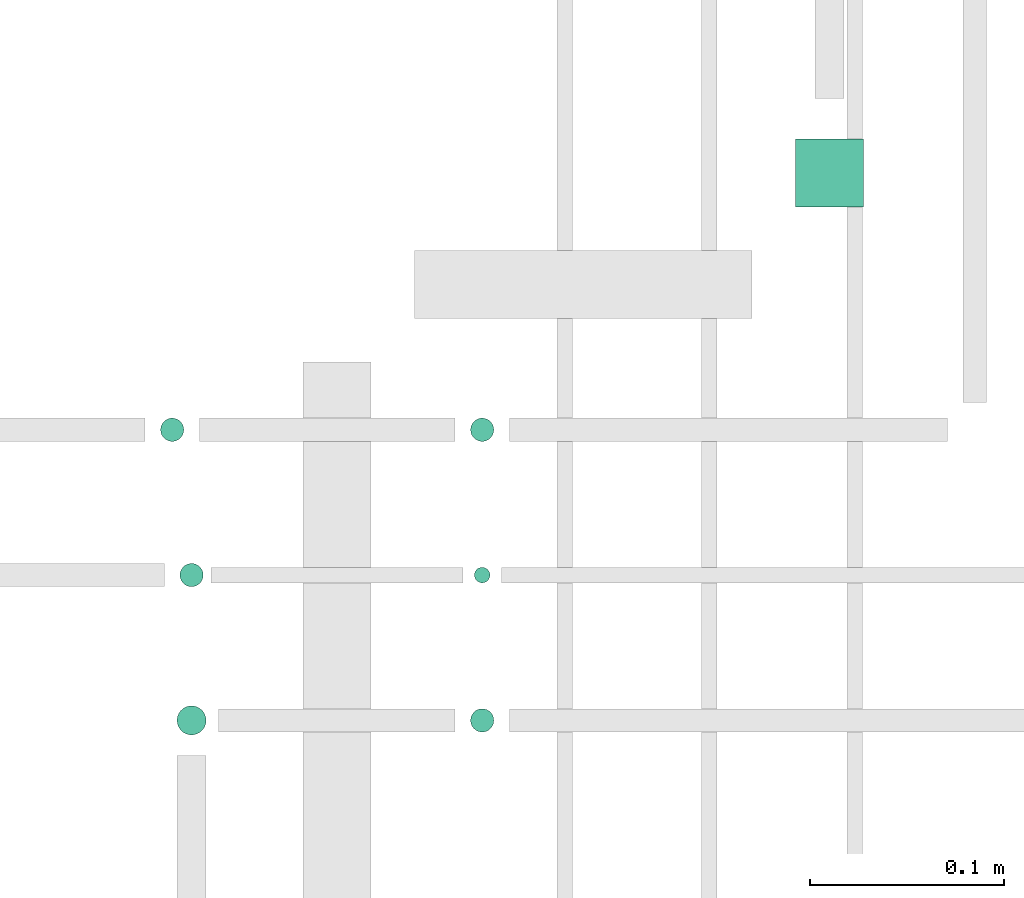
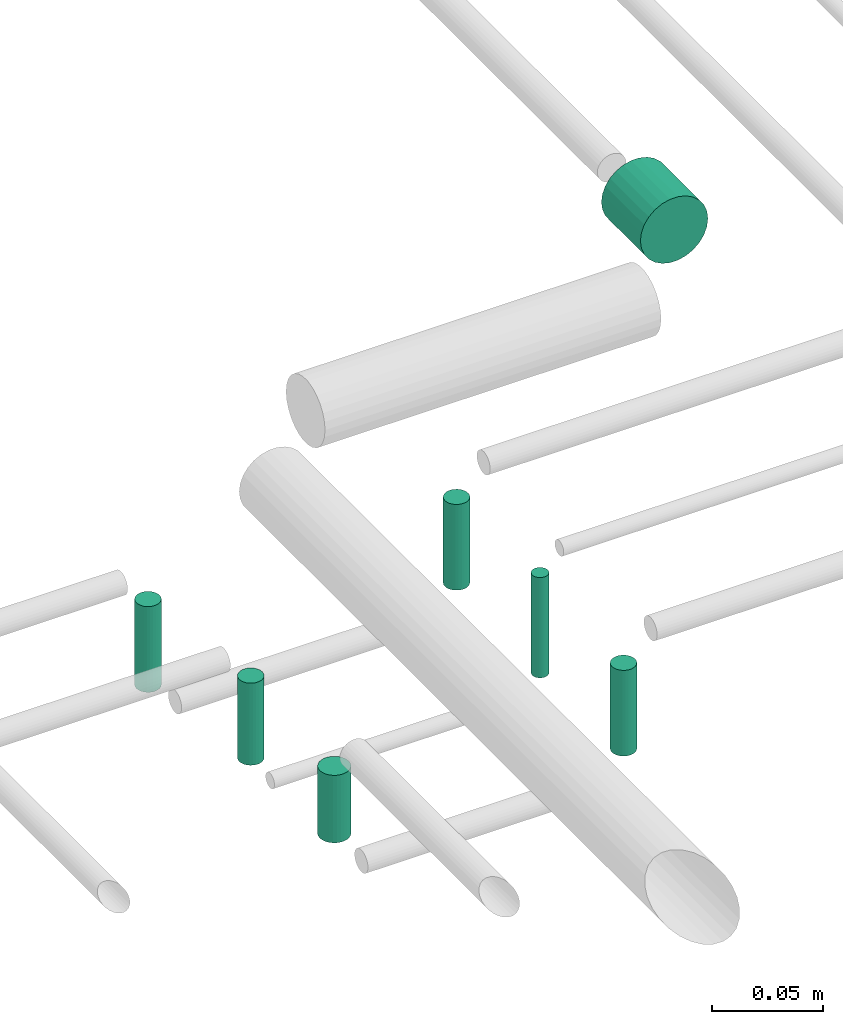
# One storey, part 320 of 331: 7 flow segments.
"""IFC2X3 building model written with IfcOpenShell, lengths in millimetres."""

import ifcopenshell
import ifcopenshell.guid

model = None  # the IFC model being written
_history = None  # IfcOwnerHistory: only IFC2X3 demands one
_inside = {}  # id of a spatial element -> (the spatial element, [elements in it])
_under = {}  # id of a project, library or spatial element -> (it, [spatial elements below it])
_declared = {}  # id of a project -> (the project, [libraries it declares])
_typed = {}  # id of a type object -> (the type object, [elements of that type])
_made_of = {}  # id of a material, layer set ... -> (it, [elements and type objects made of it])


def new_model(schema):
    """Start an empty IFC model of exactly this schema.

    Asked for "IFC4X3", IfcOpenShell would pick the latest addendum, in which some entities
    have other attributes; the version numbers below select the first issue.
    IFC2X3 requires an IfcOwnerHistory on every rooted entity: one is made here for all.
    """
    global model, _history
    if schema == "IFC4X3":
        model = ifcopenshell.file(schema_version=(4, 3, 0, 0))
    else:
        model = ifcopenshell.file(schema=schema)
    _inside.clear()
    _under.clear()
    _declared.clear()
    _typed.clear()
    _made_of.clear()
    _history = None
    if model.schema == "IFC2X3":
        org = make("IfcOrganization", Name="unknown")
        user = make(
            "IfcPersonAndOrganization",
            ThePerson=make("IfcPerson", FamilyName="unknown"),
            TheOrganization=org,
        )
        app = make(
            "IfcApplication",
            ApplicationDeveloper=org,
            Version="unknown",
            ApplicationFullName="unknown",
            ApplicationIdentifier="unknown",
        )
        _history = make(
            "IfcOwnerHistory",
            OwningUser=user,
            OwningApplication=app,
            ChangeAction="ADDED",
            CreationDate=0,
        )
    return model


def make(cls, **values):
    """One entity of the class cls with the attributes given. An attribute that is None is left unset."""
    return model.create_entity(
        cls, **{name: value for name, value in values.items() if value is not None}
    )


def entity(cls, *values):
    """Any entity or typed value of the class cls, its attributes in the order of the schema. None: left unset."""
    e = model.create_entity(cls)
    for i, value in enumerate(values):
        if value is not None:
            e[i] = value
    return e


def rooted(cls, **values):
    """An entity with a GlobalId (a new one), such as an element, a storey or a relation."""
    return make(cls, GlobalId=ifcopenshell.guid.new(), OwnerHistory=_history, **values)


def si_unit(unit_type, name, prefix=None):
    """IfcSIUnit, for example si_unit("LENGTHUNIT", "METRE", prefix="MILLI")."""
    return make("IfcSIUnit", UnitType=unit_type, Prefix=prefix, Name=name)


def converted_unit(unit_type, name, factor, base, dimensions=None, offset=None):
    """IfcConversionBasedUnit, such as the inch: factor (a typed value) times the base unit."""
    return make(
        "IfcConversionBasedUnit"
        if offset is None
        else "IfcConversionBasedUnitWithOffset",
        ConversionOffset=offset,
        Dimensions=None
        if dimensions is None
        else entity("IfcDimensionalExponents", *dimensions),
        UnitType=unit_type,
        Name=name,
        ConversionFactor=make(
            "IfcMeasureWithUnit", ValueComponent=factor, UnitComponent=base
        ),
    )


def derived_unit(unit_type, elements):
    """IfcDerivedUnit: a product of units, each with its exponent."""
    return make(
        "IfcDerivedUnit",
        Elements=[
            make("IfcDerivedUnitElement", Unit=unit, Exponent=power)
            for unit, power in elements
        ],
        UnitType=unit_type,
    )


def assignment(units):
    """IfcUnitAssignment: the units of a project."""
    return None if units is None else make("IfcUnitAssignment", Units=units)


def point(xyz):
    """IfcCartesianPoint."""
    return None if xyz is None else make("IfcCartesianPoint", Coordinates=xyz)


def direction(xyz):
    """IfcDirection."""
    return None if xyz is None else make("IfcDirection", DirectionRatios=xyz)


def frame(location, z_axis=None, x_axis=None):
    """IfcAxis2Placement3D, a coordinate frame: its origin and axes. An axis left out is left unset."""
    return make(
        "IfcAxis2Placement3D",
        Location=point(location),
        Axis=direction(z_axis),
        RefDirection=direction(x_axis),
    )


def frame_2d(location, x_axis=None):
    """IfcAxis2Placement2D, a coordinate frame in the plane: its origin and x axis."""
    return make(
        "IfcAxis2Placement2D", Location=point(location), RefDirection=direction(x_axis)
    )


def origin():
    """The frame at (0, 0, 0) with its axes left unset."""
    return frame((0.0, 0.0, 0.0))


def origin_2d_with_axis():
    """The frame at (0, 0) in the plane with the x axis (1, 0) written out."""
    return frame_2d((0.0, 0.0), x_axis=(1.0, 0.0))


def place(relative_to, where):
    """IfcLocalPlacement: puts the frame where relative to a parent placement (None: the world)."""
    return make(
        "IfcLocalPlacement", PlacementRelTo=relative_to, RelativePlacement=where
    )


def context(
    kind, dimensions, precision=None, world=None, true_north=None, identifier=None
):
    """IfcGeometricRepresentationContext, for example the 3D "Model" context."""
    return make(
        "IfcGeometricRepresentationContext",
        ContextIdentifier=identifier,
        ContextType=kind,
        CoordinateSpaceDimension=dimensions,
        Precision=precision,
        WorldCoordinateSystem=world,
        TrueNorth=true_north,
    )


def subcontext(parent, identifier, kind, view, scale=None):
    """IfcGeometricRepresentationSubContext, for example "Body" below "Model"."""
    return make(
        "IfcGeometricRepresentationSubContext",
        ContextIdentifier=identifier,
        ContextType=kind,
        ParentContext=parent,
        TargetScale=scale,
        TargetView=view,
    )


def project(units=None, contexts=None):
    """IfcProject with its units and contexts."""
    return rooted(
        "IfcProject",
        Name="project",
        RepresentationContexts=contexts,
        UnitsInContext=assignment(units),
    )


def spatial(cls, under=None, at=None, **own):
    """A site, building, storey or space (cls), placed at a placement, below another one or the project."""
    s = rooted(cls, ObjectPlacement=at, **own)
    if under is not None:
        _under.setdefault(under.id(), (under, []))[1].append(s)
    return s


def profile(cls, at=None, kind="AREA", **sizes):
    """A parametric profile (cls). Its sizes go by their IFC names, for example OverallWidth=200.0."""
    return make(cls, ProfileType=kind, Position=at, **sizes)


def circle(**sizes):
    """IfcCircleProfileDef."""
    return profile("IfcCircleProfileDef", **sizes)


def extrude(swept, where, along, depth):
    """IfcExtrudedAreaSolid: the profile swept, set in the frame where, extruded along a direction by depth."""
    return make(
        "IfcExtrudedAreaSolid",
        SweptArea=swept,
        Position=where,
        ExtrudedDirection=direction(along),
        Depth=depth,
    )


def shape(context_of_items, identifier, shape_type, items):
    """IfcShapeRepresentation: the items that make up one representation, for example the "Body"."""
    return make(
        "IfcShapeRepresentation",
        ContextOfItems=context_of_items,
        RepresentationIdentifier=identifier,
        RepresentationType=shape_type,
        Items=items,
    )


def made_of(thing, what):
    """Note that an element or type object is made of a material, layer set ...; save() writes the relation."""
    if what is not None:
        _made_of.setdefault(what.id(), (what, []))[1].append(thing)
    return thing


def type_object(cls, material=None, **own):
    """A type object (cls), such as IfcWallType, which elements share."""
    return made_of(rooted(cls, **own), material)


def element(
    cls,
    number,
    at=None,
    inside=None,
    cuts=None,
    type_object=None,
    material=None,
    context=None,
    identifier="Body",
    shape_type=None,
    held_by="IfcProductDefinitionShape",
    body=None,
    shapes=None,
    **own,
):
    """One element of the class cls, such as IfcWall. Its Tag is "e" and its number.

    at: its placement. inside: the storey or other place that contains it. cuts: it is an
    opening in that element (IfcRelVoidsElement). A single representation is given by context,
    identifier, shape_type and body (its items); several are given by shapes. held_by: the class
    of the entity that holds the representations. save() writes the other relations.
    """
    e = rooted(cls, Tag="e%d" % number, ObjectPlacement=at, **own)
    if body is not None:
        shapes = [shape(context, identifier, shape_type, body)]
    if shapes is not None:
        e.Representation = make(held_by, Representations=shapes)
    if inside is not None:
        _inside.setdefault(inside.id(), (inside, []))[1].append(e)
    if cuts is not None:
        rooted(
            "IfcRelVoidsElement", RelatingBuildingElement=cuts, RelatedOpeningElement=e
        )
    if type_object is not None:
        _typed.setdefault(type_object.id(), (type_object, []))[1].append(e)
    return made_of(e, material)


def aggregate(whole, parts):
    """IfcRelAggregates: a whole, such as a stair, and the parts it consists of."""
    return rooted("IfcRelAggregates", RelatingObject=whole, RelatedObjects=parts)


def save(model, path):
    """Write the relations noted so far, then the file.

    IfcRelAggregates (storeys below a building ...), IfcRelContainedInSpatialStructure (elements
    in a storey), IfcRelDefinesByType, IfcRelAssociatesMaterial and IfcRelDeclares: one each for
    every whole, place, type object, material and project.
    """
    for whole, parts in _under.values():
        aggregate(whole, parts)
    for where, things in _inside.values():
        rooted(
            "IfcRelContainedInSpatialStructure",
            RelatedElements=things,
            RelatingStructure=where,
        )
    for kind, things in _typed.values():
        rooted("IfcRelDefinesByType", RelatedObjects=things, RelatingType=kind)
    for what, things in _made_of.values():
        rooted("IfcRelAssociatesMaterial", RelatedObjects=things, RelatingMaterial=what)
    for by, libraries in _declared.values():
        rooted("IfcRelDeclares", RelatingContext=by, RelatedDefinitions=libraries)
    model.write(path)


model = new_model("IFC2X3")

# Units and contexts
model_context = context("Model", 3, precision=0.01, world=origin(), true_north=direction((6.12303176911189e-17, 1.0)))
body_context = subcontext(model_context, "Body", "Model", "MODEL_VIEW")
ifc_project = project(units=[si_unit("LENGTHUNIT", "METRE", prefix="MILLI"), si_unit("AREAUNIT", "SQUARE_METRE"), si_unit("VOLUMEUNIT", "CUBIC_METRE"), converted_unit("PLANEANGLEUNIT", "DEGREE", entity("IfcRatioMeasure", 0.0174532925199433), si_unit("PLANEANGLEUNIT", "RADIAN"), dimensions=[0, 0, 0, 0, 0, 0, 0]), si_unit("MASSUNIT", "GRAM", prefix="KILO"), derived_unit("MASSDENSITYUNIT", [(si_unit("MASSUNIT", "GRAM", prefix="KILO"), 1), (si_unit("LENGTHUNIT", "METRE"), -3)]), derived_unit("MOMENTOFINERTIAUNIT", [(si_unit("LENGTHUNIT", "METRE"), 4)]), si_unit("TIMEUNIT", "SECOND"), si_unit("FREQUENCYUNIT", "HERTZ"), si_unit("THERMODYNAMICTEMPERATUREUNIT", "DEGREE_CELSIUS"), derived_unit("THERMALTRANSMITTANCEUNIT", [(si_unit("MASSUNIT", "GRAM", prefix="KILO"), 1), (si_unit("THERMODYNAMICTEMPERATUREUNIT", "KELVIN"), -1), (si_unit("TIMEUNIT", "SECOND"), -3)]), derived_unit("VOLUMETRICFLOWRATEUNIT", [(si_unit("LENGTHUNIT", "METRE"), 3), (si_unit("TIMEUNIT", "SECOND"), -1)]), derived_unit("MASSFLOWRATEUNIT", [(si_unit("MASSUNIT", "GRAM", prefix="KILO"), 1), (si_unit("TIMEUNIT", "SECOND"), -1)]), derived_unit("ROTATIONALFREQUENCYUNIT", [(si_unit("TIMEUNIT", "SECOND"), -1)]), si_unit("ELECTRICCURRENTUNIT", "AMPERE"), si_unit("ELECTRICVOLTAGEUNIT", "VOLT"), si_unit("POWERUNIT", "WATT"), si_unit("FORCEUNIT", "NEWTON", prefix="KILO"), si_unit("ILLUMINANCEUNIT", "LUX"), si_unit("LUMINOUSFLUXUNIT", "LUMEN"), si_unit("LUMINOUSINTENSITYUNIT", "CANDELA"), derived_unit("USERDEFINED", [(si_unit("MASSUNIT", "GRAM", prefix="KILO"), -1), (si_unit("LENGTHUNIT", "METRE"), -2), (si_unit("TIMEUNIT", "SECOND"), 3), (si_unit("LUMINOUSFLUXUNIT", "LUMEN"), 1)]), derived_unit("LINEARVELOCITYUNIT", [(si_unit("LENGTHUNIT", "METRE"), 1), (si_unit("TIMEUNIT", "SECOND"), -1)]), si_unit("PRESSUREUNIT", "PASCAL"), derived_unit("USERDEFINED", [(si_unit("LENGTHUNIT", "METRE"), -2), (si_unit("MASSUNIT", "GRAM", prefix="KILO"), 1), (si_unit("TIMEUNIT", "SECOND"), -2)]), derived_unit("LINEARFORCEUNIT", [(si_unit("MASSUNIT", "GRAM", prefix="KILO"), 1), (si_unit("LENGTHUNIT", "METRE"), 1), (si_unit("TIMEUNIT", "SECOND"), -2), (si_unit("LENGTHUNIT", "METRE"), -1)]), derived_unit("PLANARFORCEUNIT", [(si_unit("MASSUNIT", "GRAM", prefix="KILO"), 1), (si_unit("LENGTHUNIT", "METRE"), 1), (si_unit("TIMEUNIT", "SECOND"), -2), (si_unit("LENGTHUNIT", "METRE"), -2)])], contexts=[model_context])

# Site, building, storey
site_placement = place(None, frame((0.0, -0.00077364408347762, 0.0)))
site = spatial("IfcSite", under=ifc_project, at=site_placement, CompositionType="ELEMENT")
building_placement = place(site_placement, origin())
building = spatial("IfcBuilding", under=site, at=building_placement, CompositionType="ELEMENT")
storey_placement = place(building_placement, origin())
storey = spatial("IfcBuildingStorey", under=building, at=storey_placement, CompositionType="ELEMENT", Elevation=0.0)

# Flow segments
pipe_segment_type = type_object("IfcPipeSegmentType", PredefinedType="NOTDEFINED")
flow_segment_1_placement = place(storey_placement, frame((60001.0132627125, 17865.0, 15130.9047277641)))
element("IfcFlowSegment", 1, at=flow_segment_1_placement, inside=storey, type_object=pipe_segment_type, context=body_context, shape_type="SweptSolid", body=[
    extrude(circle(Radius=17.5, at=origin_2d_with_axis()), frame((19.0952722359119, 0.0, 19.0952722359163), z_axis=(0.0, 1.0, 0.0), x_axis=(-1.0, 0.0, 0.0)), (0.0, 0.0, 1.0), 35.000000000005),
])
flow_segment_2_placement = place(storey_placement, frame((59833.2529497117, 17742.4047496789, 15089.0)))
element("IfcFlowSegment", 2, at=flow_segment_2_placement, inside=storey, type_object=pipe_segment_type, context=body_context, shape_type="SweptSolid", body=[
    extrude(circle(Radius=6.0, at=origin_2d_with_axis()), frame((7.59527223591454, 7.5952722359167, 0.0), z_axis=(0.0, 0.0, 1.0), x_axis=(-1.0, 0.0, 0.0)), (0.0, 0.0, 1.0), 47.000000000011),
])
flow_segment_3_placement = place(storey_placement, frame((59835.2529497117, 17669.4047496789, 15085.0)))
element("IfcFlowSegment", 3, at=flow_segment_3_placement, inside=storey, type_object=pipe_segment_type, context=body_context, shape_type="SweptSolid", body=[
    extrude(circle(Radius=4.0, at=origin_2d_with_axis()), frame((5.59527223591499, 5.59527223591499, 0.0), z_axis=(0.0, 0.0, 1.0), x_axis=(-1.0, 0.0, 0.0)), (0.0, 0.0, 1.0), 55.0000000000113),
])
flow_segment_4_placement = place(storey_placement, frame((59833.2529497117, 17592.4047496789, 15089.0)))
element("IfcFlowSegment", 4, at=flow_segment_4_placement, inside=storey, type_object=pipe_segment_type, context=body_context, shape_type="SweptSolid", body=[
    extrude(circle(Radius=6.0, at=frame_2d((0.0, -2.16573425859679e-12), x_axis=(1.0, 0.0))), frame((7.59527223591454, 7.59527223591454, 0.0), z_axis=(0.0, 0.0, 1.0), x_axis=(-1.0, 0.0, 0.0)), (0.0, 0.0, 1.0), 47.000000000011),
])
flow_segment_5_placement = place(storey_placement, frame((59681.7529497117, 17590.9047496789, 15095.0)))
element("IfcFlowSegment", 5, at=flow_segment_5_placement, inside=storey, type_object=pipe_segment_type, context=body_context, shape_type="SweptSolid", body=[
    extrude(circle(Radius=7.5, at=origin_2d_with_axis()), frame((9.09527223591419, 9.09527223591636, 0.0), z_axis=(0.0, 0.0, 1.0), x_axis=(-1.0, 0.0, 0.0)), (0.0, 0.0, 1.0), 37.0000000000132),
])
flow_segment_6_placement = place(storey_placement, frame((59683.2529497117, 17667.4047496789, 15091.0)))
element("IfcFlowSegment", 6, at=flow_segment_6_placement, inside=storey, type_object=pipe_segment_type, context=body_context, shape_type="SweptSolid", body=[
    extrude(circle(Radius=6.0, at=origin_2d_with_axis()), frame((7.59527223591454, 7.5952722359167, 0.0), z_axis=(0.0, 0.0, 1.0), x_axis=(-1.0, 0.0, 0.0)), (0.0, 0.0, 1.0), 45.0000000000114),
])
flow_segment_7_placement = place(storey_placement, frame((59673.2529497116, 17742.4047496789, 15089.0)))
element("IfcFlowSegment", 7, at=flow_segment_7_placement, inside=storey, type_object=pipe_segment_type, context=body_context, shape_type="SweptSolid", body=[
    extrude(circle(Radius=6.0, at=origin_2d_with_axis()), frame((7.59527223591454, 7.5952722359167, 0.0), z_axis=(0.0, 0.0, 1.0), x_axis=(-1.0, 0.0, 0.0)), (0.0, 0.0, 1.0), 47.0000000000131),
])

save(model, "model.ifc")
